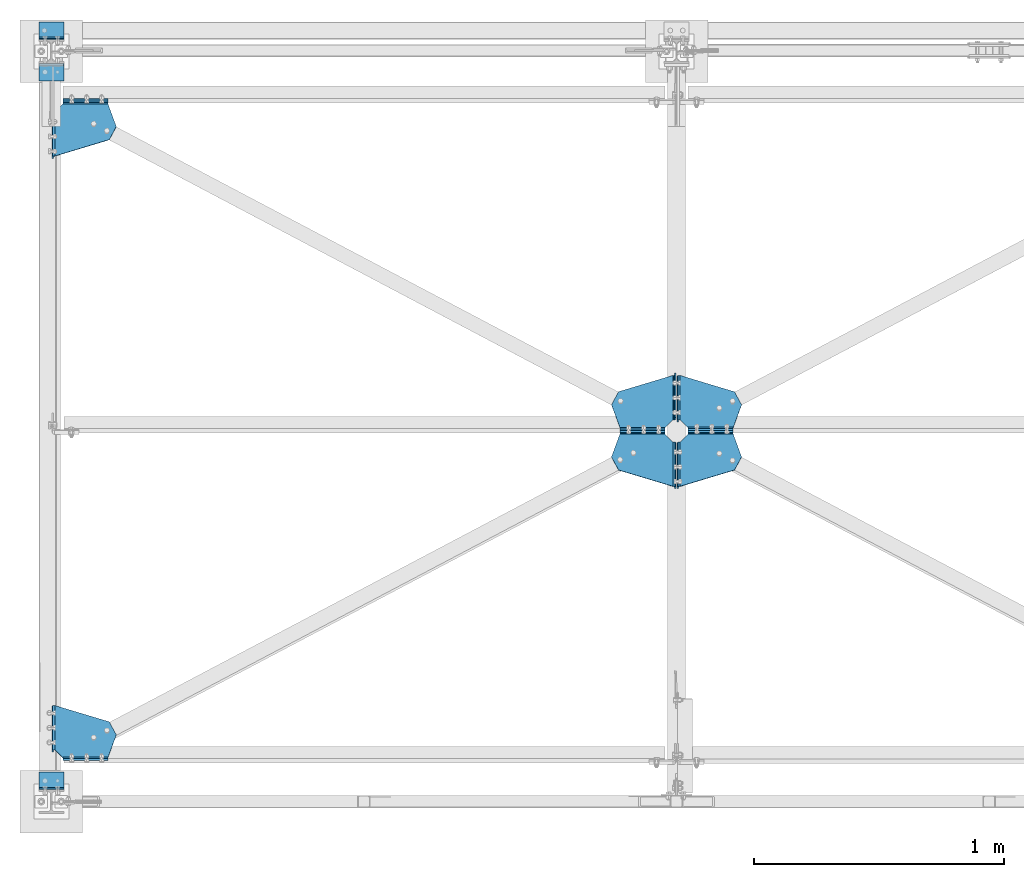
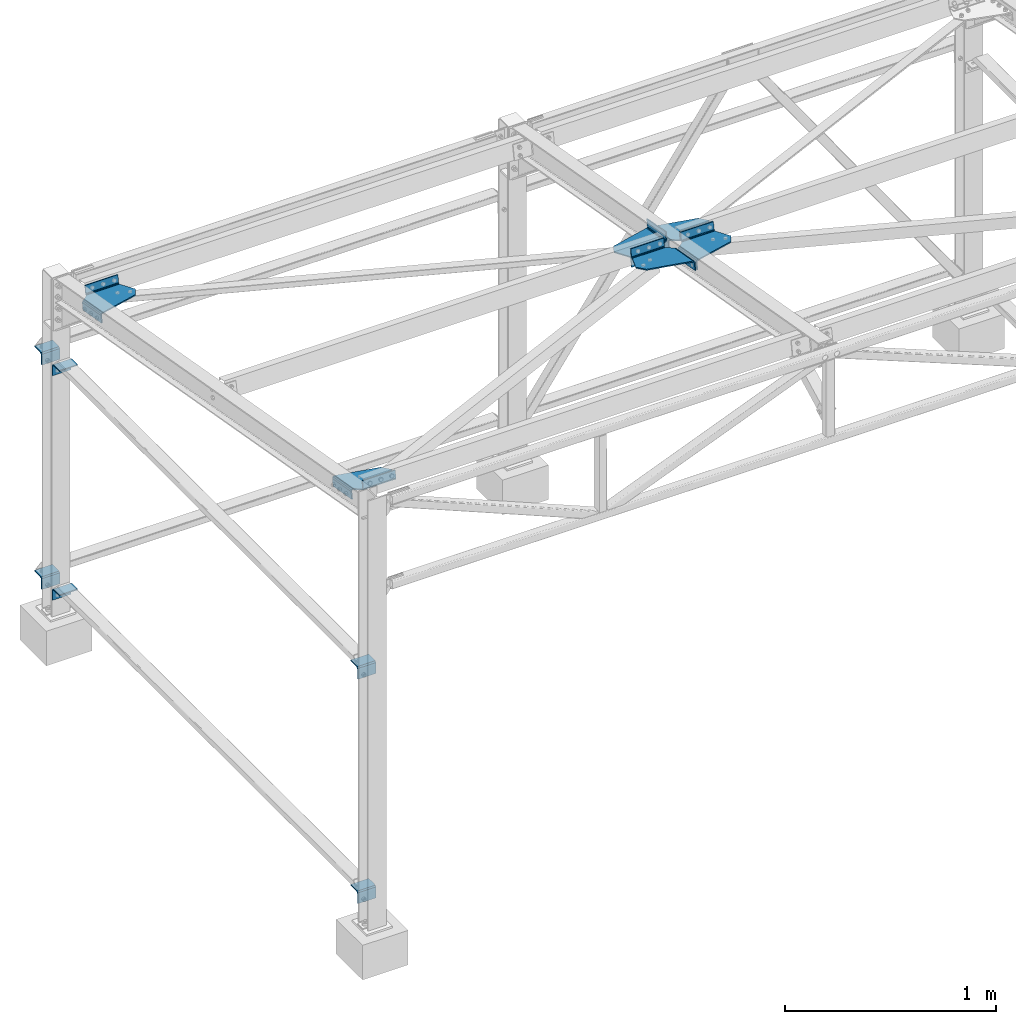
# One storey, part 14 of 28: 12 beams, 12 elements without a shape of their own.
"""IFC2X3 building model written with IfcOpenShell, lengths in millimetres."""

from ifc_helpers import new_model, si_unit, frame, origin_with_axes, place, context, subcontext, project, spatial, faceted_brep, material, type_object, element, aggregate, save


model = new_model("IFC2X3")

# Units and contexts
model_context = context("Model", 3, precision=1e-05, world=origin_with_axes())
body_context = subcontext(model_context, "Body", "Model", "MODEL_VIEW")
ifc_project = project(units=[si_unit("LENGTHUNIT", "METRE", prefix="MILLI"), si_unit("AREAUNIT", "SQUARE_METRE"), si_unit("VOLUMEUNIT", "CUBIC_METRE"), si_unit("MASSUNIT", "GRAM", prefix="KILO"), si_unit("TIMEUNIT", "SECOND"), si_unit("PLANEANGLEUNIT", "RADIAN"), si_unit("SOLIDANGLEUNIT", "STERADIAN"), si_unit("THERMODYNAMICTEMPERATUREUNIT", "DEGREE_CELSIUS"), si_unit("LUMINOUSINTENSITYUNIT", "LUMEN")], contexts=[model_context])

# Site, building, storey
site_placement = place(None, origin_with_axes())
site = spatial("IfcSite", under=ifc_project, at=site_placement, CompositionType="ELEMENT")
building_placement = place(site_placement, origin_with_axes())
building = spatial("IfcBuilding", under=site, at=building_placement, Name="Undefined", CompositionType="ELEMENT")
storey_placement = place(building_placement, origin_with_axes())
storey = spatial("IfcBuildingStorey", under=building, at=storey_placement, Name="Undefined", CompositionType="ELEMENT", Elevation=0.0)

# Assembly, beam
assembly_1_placement = place(storey_placement, origin_with_axes())
assembly_1 = element("IfcElementAssembly", 1, at=assembly_1_placement, inside=storey, Name="2", AssemblyPlace="NOTDEFINED", PredefinedType="NOTDEFINED")
ifc_material = material(Name="STEEL/S235JR")
beam_type_1 = type_object("IfcBeamType", PredefinedType="NOTDEFINED")
beam_1_placement = place(assembly_1_placement, frame((2485.82560922523, 1526.55311107342, 2359.69186909693), z_axis=(-0.999999997271612, 7.27429091355134e-05, -1.28548072275407e-05), x_axis=(7.38699999887347e-05, 0.984742281847075, -0.174019058972976)))
beam_1 = element("IfcBeam", 2, at=beam_1_placement, type_object=beam_type_1, material=ifc_material, Name="2", context=body_context, shape_type="Brep", body=[
    faceted_brep([(-32.1671295166939, -2.99999983428825, 32.1499938964121), (-32.1671295166839, -2.99999983429416, 212.154846191318), (-40.6403164354399, 0.509709106417176, 212.152998303093), (-40.6403164354474, 0.509709106422179, 32.1499938964289), (180.004760742243, -3.00000038144935, -3.91082721762359e-11), (0.0, -3.00000009420476, 0.0), (-1.52675529534463e-05, -4.75735959676012, -4.24263979950592), (180.002939800075, -4.75735959674284, -4.24263979952093), (180.001118816501, -51.0000006712148, -11.9999984741489), (180.00111885851, -9.00000043278169, -11.9999984741462), (180.00111885851, -9.00000043278214, -5.9999984741462), (180.001118816501, -51.0000006712148, -5.99999847414938), (-3.05263461086724e-05, -8.99999977819925, -5.99999809267229), (-2.55926208865276e-05, -51.0000002529223, -5.99999847413756), (-2.55926211139013e-05, -51.0000002529223, -11.9999984741371), (-2.55506129178684e-05, -9.00000025293548, -11.9999984741339), (0.0, 2.99999999999272, 0.0), (180.004760742242, 2.99999961854974, -3.86535248253495e-11), (180.002939800075, -0.514719370688454, -8.4852809477029), (-1.52675536355673e-05, -0.514719370705279, -8.4852809476879), (113.656394958525, 3.00000000000182, 217.484680175736), (113.656394958525, -2.99999999999727, 217.484680175736), (60.7738876343287, -3.00000000000136, 245.829696655227), (60.7738876343283, 2.99999999999773, 245.829696655228), (-32.1671295165343, 2.99999999999181, 212.154846191372), (-32.1671295166941, 3.00000016571084, 32.1499938964125), (-36.3976757462415, 4.75234979145444, 32.1499938964294), (-36.397675746234, 4.75234979144943, 212.152998303094), (-44.1500255336107, 8.98289602876866, 212.151145934964), (-38.1500255336107, 8.98289602275418, 212.151145934963), (-44.1500255336027, 9.0000000174291, 32.1500015258139), (-44.1500254914999, 51.0000000166533, 32.1500015258243), (-38.1500254914999, 51.0000000106388, 32.1500015258239), (-38.1500253678239, 8.98289602272507, 32.1499938964253), (-44.1500254914909, 51.0000000166137, 212.151145934974), (-38.1500254914909, 51.0000000105988, 212.151145934974)], [[[0, 1, 2, 3]], [[4, 5, 6, 7]], [[8, 9, 10, 11]], [[10, 12, 13, 11]], [[14, 8, 11, 13]], [[15, 9, 8, 14]], [[16, 17, 18, 19]], [[15, 19, 18, 9]], [[14, 13, 12, 6, 5, 16, 19, 15]], [[10, 7, 6, 12]], [[9, 18, 17, 4, 7, 10]], [[17, 20, 21, 4]], [[22, 21, 20, 23]], [[1, 22, 23, 24]], [[0, 5, 4, 21, 22, 1]], [[25, 16, 5, 0]], [[24, 23, 20, 17, 16, 25]], [[24, 25, 26, 27]], [[28, 2, 1, 24, 27, 29]], [[30, 3, 2, 28]], [[31, 32, 33, 26, 25, 0, 3, 30]], [[29, 27, 26, 33]], [[34, 31, 30, 28]], [[31, 34, 35, 32]], [[32, 35, 29, 33]], [[34, 28, 29, 35]]]),
])
aggregate(assembly_1, [beam_1])

assembly_2_placement = place(storey_placement, origin_with_axes())
assembly_2 = element("IfcElementAssembly", 3, at=assembly_2_placement, inside=storey, Name="2", AssemblyPlace="NOTDEFINED", PredefinedType="NOTDEFINED")
beam_2_placement = place(assembly_2_placement, frame((2514.35000069038, 1259.97009350943, 2406.80117727692), z_axis=(1.0, 0.0, 0.0), x_axis=(0.0, 0.984742283021841, -0.174019068003859)))
beam_2 = element("IfcBeam", 4, at=beam_2_placement, type_object=beam_type_1, material=ifc_material, Name="2", context=body_context, shape_type="Brep", body=[
    faceted_brep([(212.171890258304, 3.00000015340356, 32.1499938964184), (212.171890258359, 3.00000015328351, 212.154846191022), (216.402436487897, 4.75234977903438, 212.152999877545), (216.402436487869, 4.75234977916534, 32.1499938964134), (0.0, 2.99999999999272, 0.0), (180.004760742242, 2.99999961854974, -3.86535248253495e-11), (180.004776007459, -0.514719288806191, -8.4852808684177), (0.00182344081565589, -0.514719288739798, -8.48528086851638), (0.00364192279562303, -51.0000006707974, -5.99999847590698), (0.00364686610055287, -8.99999966160567, -5.99999809708106), (0.00364188078174266, -9.00000043237287, -11.9999984758915), (0.00364192279812414, -51.0000006707951, -11.999998475907), (180.00478628962, -9.00000025209329, -11.9999984758178), (180.00478633164, -51.0000002520987, -11.9999984758333), (180.004786331637, -51.0000002521006, -5.99999847583331), (180.004786289618, -9.00000025209602, -5.99999847581785), (180.004760742243, -3.00000038144935, -3.91082721762359e-11), (0.0, -3.00000009420476, 0.0), (0.00182344081167685, -4.75735955658729, -4.24263976212569), (180.004776007455, -4.75735955665368, -4.24263976202747), (66.3483657821899, -3.00000000178579, 217.484680173498), (66.3483657821853, 2.99999999821421, 217.484680173498), (119.230873106326, 2.99999999825377, 245.829696652969), (119.230873106331, -3.00000000174623, 245.829696652969), (212.171890258362, -2.99999984671604, 212.154846191018), (212.171890262616, -3.0000000016762, 32.1500015232709), (220.645077177092, 0.509709094149912, 32.1499938964098), (220.64507717712, 0.509709094018945, 212.152999877541), (218.154786275127, 8.98289600998714, 212.151145934432), (224.154786275127, 8.98289601609486, 212.151145934433), (218.154786275146, 8.99999999865349, 32.1500015255733), (218.154786232393, 50.9999999979341, 32.1500015229508), (224.154786232393, 51.0000000040418, 32.1500015229522), (224.154786109435, 8.98289601641636, 32.1499938964125), (218.154786232358, 50.9999999979873, 212.151145931813), (224.154786232357, 51.000000004095, 212.151145931814)], [[[0, 1, 2, 3]], [[4, 5, 6, 7]], [[8, 9, 10, 11]], [[10, 12, 13, 11]], [[14, 8, 11, 13]], [[15, 9, 8, 14]], [[16, 17, 18, 19]], [[15, 19, 18, 9]], [[14, 13, 12, 6, 5, 16, 19, 15]], [[10, 7, 6, 12]], [[9, 18, 17, 4, 7, 10]], [[17, 20, 21, 4]], [[22, 21, 20, 23]], [[1, 22, 23, 24]], [[0, 5, 4, 21, 22, 1]], [[25, 16, 5, 0]], [[24, 23, 20, 17, 16, 25]], [[24, 25, 26, 27]], [[28, 2, 1, 24, 27, 29]], [[30, 3, 2, 28]], [[31, 32, 33, 26, 25, 0, 3, 30]], [[29, 27, 26, 33]], [[34, 31, 30, 28]], [[31, 34, 35, 32]], [[32, 35, 29, 33]], [[34, 28, 29, 35]]]),
])
aggregate(assembly_2, [beam_2])

assembly_3_placement = place(storey_placement, origin_with_axes())
assembly_3 = element("IfcElementAssembly", 5, at=assembly_3_placement, inside=storey, Name="2", AssemblyPlace="NOTDEFINED", PredefinedType="NOTDEFINED")
beam_3_placement = place(assembly_3_placement, frame((2514.34999981113, 1526.23027996638, 2359.74891680608), z_axis=(1.0, 0.0, 0.0), x_axis=(0.0, 0.984742283021841, -0.174019068003859)))
beam_3 = element("IfcBeam", 6, at=beam_3_placement, type_object=beam_type_1, material=ifc_material, Name="2", context=body_context, shape_type="Brep", body=[
    faceted_brep([(-32.1671295166939, -2.99999983428825, 32.1499938964121), (-32.1671295166839, -2.99999983429416, 212.154846191318), (-40.6403164354399, 0.509709106417176, 212.152998303093), (-40.6403164354474, 0.509709106422179, 32.1499938964289), (180.004760742243, -3.00000038144935, -3.91082721762359e-11), (0.0, -3.00000009420476, 0.0), (-1.52675529534463e-05, -4.75735959676012, -4.24263979950592), (180.002939800075, -4.75735959674284, -4.24263979952093), (180.001118816501, -51.0000006712148, -11.9999984741489), (180.00111885851, -9.00000043278169, -11.9999984741462), (180.00111885851, -9.00000043278214, -5.9999984741462), (180.001118816501, -51.0000006712148, -5.99999847414938), (-3.05263461086724e-05, -8.99999977819925, -5.99999809267229), (-2.55926208865276e-05, -51.0000002529223, -5.99999847413756), (-2.55926211139013e-05, -51.0000002529223, -11.9999984741371), (-2.55506129178684e-05, -9.00000025293548, -11.9999984741339), (0.0, 2.99999999999272, 0.0), (180.004760742242, 2.99999961854974, -3.86535248253495e-11), (180.002939800075, -0.514719370688454, -8.4852809477029), (-1.52675536355673e-05, -0.514719370705279, -8.4852809476879), (113.656394958525, 3.00000000000182, 217.484680175736), (113.656394958525, -2.99999999999727, 217.484680175736), (60.7738876343287, -3.00000000000136, 245.829696655227), (60.7738876343283, 2.99999999999773, 245.829696655228), (-32.1671295165343, 2.99999999999181, 212.154846191372), (-32.1671295166941, 3.00000016571084, 32.1499938964125), (-36.3976757462415, 4.75234979145444, 32.1499938964294), (-36.397675746234, 4.75234979144943, 212.152998303094), (-44.1500255336107, 8.98289602876866, 212.151145934964), (-38.1500255336107, 8.98289602275418, 212.151145934963), (-44.1500255336027, 9.0000000174291, 32.1500015258139), (-44.1500254914999, 51.0000000166533, 32.1500015258243), (-38.1500254914999, 51.0000000106388, 32.1500015258239), (-38.1500253678239, 8.98289602272507, 32.1499938964253), (-44.1500254914909, 51.0000000166137, 212.151145934974), (-38.1500254914909, 51.0000000105988, 212.151145934974)], [[[0, 1, 2, 3]], [[4, 5, 6, 7]], [[8, 9, 10, 11]], [[10, 12, 13, 11]], [[14, 8, 11, 13]], [[15, 9, 8, 14]], [[16, 17, 18, 19]], [[15, 19, 18, 9]], [[14, 13, 12, 6, 5, 16, 19, 15]], [[10, 7, 6, 12]], [[9, 18, 17, 4, 7, 10]], [[17, 20, 21, 4]], [[22, 21, 20, 23]], [[1, 22, 23, 24]], [[0, 5, 4, 21, 22, 1]], [[25, 16, 5, 0]], [[24, 23, 20, 17, 16, 25]], [[24, 25, 26, 27]], [[28, 2, 1, 24, 27, 29]], [[30, 3, 2, 28]], [[31, 32, 33, 26, 25, 0, 3, 30]], [[29, 27, 26, 33]], [[34, 31, 30, 28]], [[31, 34, 35, 32]], [[32, 35, 29, 33]], [[34, 28, 29, 35]]]),
])
aggregate(assembly_3, [beam_3])

assembly_4_placement = place(storey_placement, origin_with_axes())
assembly_4 = element("IfcElementAssembly", 7, at=assembly_4_placement, inside=storey, Name="2", AssemblyPlace="NOTDEFINED", PredefinedType="NOTDEFINED")
beam_4_placement = place(assembly_4_placement, frame((2485.64999885867, 1259.97009239422, 2406.8011763732), z_axis=(-1.0, 0.0, 0.0), x_axis=(0.0, 0.984742283021841, -0.174019068003859)))
beam_4 = element("IfcBeam", 8, at=beam_4_placement, type_object=beam_type_1, material=ifc_material, Name="2", context=body_context, shape_type="Brep", body=[
    faceted_brep([(212.171890258362, -2.99999984671604, 212.154846191018), (212.171890262616, -3.0000000016762, 32.1500015232709), (216.402436417659, -4.75234984434974, 32.1499939661526), (216.402436417649, -4.75234984434655, 212.152999947595), (180.004760742243, -3.00000038144935, -3.91082721762359e-11), (0.0, -3.00000009420476, 0.0), (0.00182344546442437, 0.514719367938596, -8.48528094933317), (180.004776030061, 0.514719367933139, -8.48528094933909), (119.230873106326, 2.99999999825377, 245.829696652969), (66.3483657821853, 2.99999999821421, 217.484680173498), (66.3483657821899, -3.00000000178579, 217.484680173498), (119.230873106331, -3.00000000174623, 245.829696652969), (0.0, 2.99999999999272, 0.0), (180.00479128885, 9.00000107956885, -11.9999980942903), (0.00364190111224616, 9.00000037021528, -11.9999984245605), (0.00364194311600841, 51.000000608894, -11.9999984245605), (180.004786352339, 51.000000190174, -11.9999984245587), (0.00364190111201879, 9.00000037021528, -5.99999842456054), (0.00364194311600841, 51.0000006088935, -5.99999842456054), (180.004786352339, 51.000000190174, -5.99999842455873), (180.004786310335, 9.00000019020126, -5.99999842455873), (180.004760742242, 2.99999961854974, -3.86535248253495e-11), (180.004776030061, 4.75735959397207, -4.24263980113983), (0.00182344546442437, 4.75735959397753, -4.24263980113437), (212.171890258304, 3.00000015340356, 32.1499938964184), (212.171890258359, 3.00000015328351, 212.154846191022), (220.645077106859, -0.5097091593193, 212.152999947595), (220.64507710687, -0.509709159322483, 32.1499939661526), (224.154786205036, -8.98289611563087, 32.1500015982069), (224.154786205021, -8.99999985471231, 212.151146007386), (218.154786039228, -8.98289607562765, 212.15115363412), (218.154786205036, -8.98289610954862, 32.1500015982069), (218.154786162447, -51.0000000781347, 212.151146004903), (218.154786162444, -51.0000000780733, 32.1500015957245), (224.154786162445, -51.0000000841551, 32.1500015957245), (224.154786162447, -51.0000000842165, 212.151146004903)], [[[0, 1, 2, 3]], [[4, 5, 6, 7]], [[8, 9, 10, 11]], [[5, 10, 9, 12]], [[13, 14, 15, 16]], [[15, 14, 17, 18]], [[16, 15, 18, 19]], [[17, 20, 19, 18]], [[12, 21, 22, 23]], [[17, 23, 22, 20]], [[14, 6, 5, 12, 23, 17]], [[13, 7, 6, 14]], [[16, 19, 20, 22, 21, 4, 7, 13]], [[1, 4, 21, 24]], [[0, 11, 10, 5, 4, 1]], [[25, 8, 11, 0]], [[24, 21, 12, 9, 8, 25]], [[24, 25, 26, 27]], [[28, 27, 26, 29]], [[30, 3, 2, 31]], [[29, 26, 25, 0, 3, 30]], [[32, 33, 34, 35]], [[30, 32, 35, 29]], [[33, 32, 30, 31]], [[33, 31, 2, 1, 24, 27, 28, 34]], [[35, 34, 28, 29]]]),
])
aggregate(assembly_4, [beam_4])

assembly_5_placement = place(storey_placement, origin_with_axes())
assembly_5 = element("IfcElementAssembly", 9, at=assembly_5_placement, inside=storey, Name="2", AssemblyPlace="NOTDEFINED", PredefinedType="NOTDEFINED")
beam_5_placement = place(assembly_5_placement, frame((14.3500001059313, 2757.8578579446, 2142.10143063266), z_axis=(1.0, 0.0, 0.0), x_axis=(0.0, -0.984742283021841, 0.17401906800386)))
beam_5 = element("IfcBeam", 10, at=beam_5_placement, type_object=beam_type_1, material=ifc_material, Name="2", context=body_context, shape_type="Brep", body=[
    faceted_brep([(-32.1671295165343, 2.99999999999181, 212.154846191372), (-32.1671295166941, 3.00000016571084, 32.1499938964125), (-40.6403164367075, -0.509709095669223, 32.1499938980763), (-40.6403164366952, -0.509709095670132, 212.15299987956), (0.0, 2.99999999999272, 0.0), (180.004760742242, 2.99999961854974, -3.86535248253495e-11), (180.002937299718, 4.75735955505934, -4.24263976038337), (-1.52670218085404e-05, 4.7573595550889, -4.24263976037983), (60.7738876343287, -3.00000000000136, 245.829696655227), (113.656394958525, -2.99999999999727, 217.484680175736), (113.656394958525, 3.00000000000182, 217.484680175736), (60.7738876343283, 2.99999999999773, 245.829696655228), (180.004760742243, -3.00000038144935, -3.91082721762359e-11), (-2.55477848440933e-05, 9.00000025060126, -5.99999848867704), (180.001118861344, 9.00000043080399, -5.99999848867694), (180.001118819345, 51.0000006694813, -5.99999848867695), (-2.55897848546738e-05, 51.0000002505694, -5.99999848867705), (180.001113874432, 9.00000084603289, -11.9999980953256), (180.001118819345, 51.0000006694813, -11.999998488677), (-2.55897848546738e-05, 51.0000002505694, -11.9999984886771), (-2.55477848440933e-05, 9.00000025060126, -11.999998488677), (0.0, -3.00000009420476, 0.0), (-1.52670222632878e-05, 0.514719287256412, -8.48528086678614), (180.002937299717, 0.514719287227763, -8.48528086678967), (-32.1671295166939, -2.99999983428825, 32.1499938964121), (-32.1671295166839, -2.99999983429416, 212.154846191318), (-36.3976757474693, -4.75234978068238, 212.15299987956), (-36.3976757474811, -4.75234978068102, 32.149993898076), (-38.1500255347992, -9.00000000026193, 32.150001527229), (-38.1500255348169, -8.98289601158194, 212.151145936418), (-38.1500254930233, -50.9999999995471, 32.1500015391552), (-44.1500254930229, -51.0000000055152, 32.1500015391552), (-44.1500255347983, -9.00000000622958, 32.150001527229), (-44.1500253690306, -8.98289601795022, 212.151153566087), (-38.1500254930238, -50.999999999618, 212.151145948344), (-44.1500254930238, -51.0000000055852, 212.151145948344)], [[[0, 1, 2, 3]], [[4, 5, 6, 7]], [[8, 9, 10, 11]], [[5, 10, 9, 12]], [[13, 14, 15, 16]], [[15, 14, 17, 18]], [[16, 15, 18, 19]], [[17, 20, 19, 18]], [[12, 21, 22, 23]], [[17, 23, 22, 20]], [[14, 6, 5, 12, 23, 17]], [[13, 7, 6, 14]], [[16, 19, 20, 22, 21, 4, 7, 13]], [[1, 4, 21, 24]], [[0, 11, 10, 5, 4, 1]], [[25, 8, 11, 0]], [[24, 21, 12, 9, 8, 25]], [[24, 25, 26, 27]], [[28, 27, 26, 29]], [[30, 31, 32, 2, 1, 24, 27, 28]], [[33, 3, 2, 32]], [[29, 26, 25, 0, 3, 33]], [[30, 34, 35, 31]], [[34, 29, 33, 35]], [[31, 35, 33, 32]], [[34, 30, 28, 29]]]),
])
aggregate(assembly_5, [beam_5])

assembly_6_placement = place(storey_placement, origin_with_axes())
assembly_6 = element("IfcElementAssembly", 11, at=assembly_6_placement, inside=storey, Name="1", AssemblyPlace="NOTDEFINED", PredefinedType="NOTDEFINED")
beam_6_placement = place(assembly_6_placement, frame((14.3499999055751, 383.933919863615, 2561.61020728399), z_axis=(1.0, 0.0, 0.0), x_axis=(0.0, -0.984742283021841, 0.17401906800386)))
beam_6 = element("IfcBeam", 12, at=beam_6_placement, type_object=beam_type_1, material=ifc_material, Name="1", context=body_context, shape_type="Brep", body=[
    faceted_brep([(212.171890258362, -2.99999984671604, 212.154846191018), (212.171890262616, -3.0000000016762, 32.1500015232709), (216.402436417659, -4.75234984434974, 32.1499939661526), (216.402436417649, -4.75234984434655, 212.152999947595), (180.004760742243, -3.00000038144935, -3.91082721762359e-11), (0.0, -3.00000009420476, 0.0), (0.00182344546442437, 0.514719367938596, -8.48528094933317), (180.004776030061, 0.514719367933139, -8.48528094933909), (119.230873106326, 2.99999999825377, 245.829696652969), (66.3483657821853, 2.99999999821421, 217.484680173498), (66.3483657821899, -3.00000000178579, 217.484680173498), (119.230873106331, -3.00000000174623, 245.829696652969), (0.0, 2.99999999999272, 0.0), (180.00479128885, 9.00000107956885, -11.9999980942903), (0.00364190111224616, 9.00000037021528, -11.9999984245605), (0.00364194311600841, 51.000000608894, -11.9999984245605), (180.004786352339, 51.000000190174, -11.9999984245587), (0.00364190111201879, 9.00000037021528, -5.99999842456054), (0.00364194311600841, 51.0000006088935, -5.99999842456054), (180.004786352339, 51.000000190174, -5.99999842455873), (180.004786310335, 9.00000019020126, -5.99999842455873), (180.004760742242, 2.99999961854974, -3.86535248253495e-11), (180.004776030061, 4.75735959397207, -4.24263980113983), (0.00182344546442437, 4.75735959397753, -4.24263980113437), (212.171890258304, 3.00000015340356, 32.1499938964184), (212.171890258359, 3.00000015328351, 212.154846191022), (220.645077106859, -0.5097091593193, 212.152999947595), (220.64507710687, -0.509709159322483, 32.1499939661526), (224.154786275888, -9.00000001742183, 32.1500015258126), (224.154786275905, -8.98289602874456, 212.151145935003), (224.154786162445, -51.0000000841551, 32.1500015957245), (218.154786162444, -51.0000000780733, 32.1500015957245), (218.154786275888, -9.00000001144599, 32.1500015258126), (218.154786039228, -8.98289607562765, 212.15115363412), (218.154786162447, -51.0000000781347, 212.151146004903), (224.154786162447, -51.0000000842165, 212.151146004903)], [[[0, 1, 2, 3]], [[4, 5, 6, 7]], [[8, 9, 10, 11]], [[5, 10, 9, 12]], [[13, 14, 15, 16]], [[15, 14, 17, 18]], [[16, 15, 18, 19]], [[17, 20, 19, 18]], [[12, 21, 22, 23]], [[17, 23, 22, 20]], [[14, 6, 5, 12, 23, 17]], [[13, 7, 6, 14]], [[16, 19, 20, 22, 21, 4, 7, 13]], [[1, 4, 21, 24]], [[0, 11, 10, 5, 4, 1]], [[25, 8, 11, 0]], [[24, 21, 12, 9, 8, 25]], [[24, 25, 26, 27]], [[28, 27, 26, 29]], [[30, 31, 32, 2, 1, 24, 27, 28]], [[33, 3, 2, 32]], [[29, 26, 25, 0, 3, 33]], [[34, 31, 30, 35]], [[35, 29, 33, 34]], [[31, 34, 33, 32]], [[35, 30, 28, 29]]]),
])
aggregate(assembly_6, [beam_6])

assembly_7_placement = place(storey_placement, origin_with_axes())
assembly_7 = element("IfcElementAssembly", 13, at=assembly_7_placement, inside=storey, Name="Support-Lisse", AssemblyPlace="NOTDEFINED", PredefinedType="NOTDEFINED")
beam_type_2 = type_object("IfcBeamType", PredefinedType="NOTDEFINED")
beam_7_placement = place(assembly_7_placement, frame((-50.0000000003879, 2949.0000000009, 361.999895901674), z_axis=(0.0, 0.0, -1.0), x_axis=(1.0, 0.0, 0.0)))
beam_7 = element("IfcBeam", 14, at=beam_7_placement, type_object=beam_type_2, material=ifc_material, Name="Support-Lisse", context=body_context, shape_type="Brep", body=[
    faceted_brep([(100.000000000007, -0.588457268122056, -8.99999999999545), (-6.11066752753686e-13, -0.588457268120692, -8.99999999999545), (-1.12976294985856e-12, 5.99999999999682, -15.5884572681151), (100.000000000006, 5.99999999999545, -15.5884572681151), (100.000000000007, -3.00000000000136, 2.95585778076202e-12), (0.0, -3.00000009420476, 0.0), (100.000000000009, -3.0, 52.0000000000091), (1.81898940354586e-12, -3.0, 52.0000000000086), (100.000000000009, 3.0, 52.0000000000091), (1.81898940354586e-12, 3.0, 52.0000000000086), (0.0, 2.99999999999272, 0.0), (100.000000000007, 2.99999999999864, 2.95585778076202e-12), (100.000000000007, 4.60769515458469, -5.99999999999602), (-5.40012479177676e-13, 4.60769515458605, -5.99999999999602), (100.000000000006, 8.99999999999636, -10.3923048454091), (-1.08713038571295e-12, 8.99999999999773, -10.3923048454091), (7.105427357601e-15, 14.9999999999968, -11.9999999999886), (100.000000000007, 14.9999999999968, -11.9999999999889), (100.000000000006, 14.9999999999932, -17.999999999997), (-7.105427357601e-15, 14.9999999999968, -17.9999999999886), (100.000000000005, 66.9999999999968, -17.9999999999886), (100.000000000005, 66.9999999999968, -11.9999999999886), (-1.82609483090346e-12, 66.9999999999968, -17.9999999999884), (-1.81188397618826e-12, 66.9999999999968, -11.9999999999884)], [[[0, 1, 2, 3]], [[4, 5, 1, 0]], [[4, 6, 7, 5]], [[7, 6, 8, 9]], [[10, 9, 8, 11]], [[10, 11, 12, 13]], [[13, 12, 14, 15]], [[16, 15, 14, 17]], [[18, 3, 2, 19]], [[20, 21, 17, 14, 12, 11, 8, 6, 4, 0, 3, 18]], [[20, 22, 23, 21]], [[20, 18, 19, 22]], [[22, 19, 2, 1, 5, 7, 9, 10, 13, 15, 16, 23]], [[17, 21, 23, 16]]]),
])
aggregate(assembly_7, [beam_7])

assembly_8_placement = place(storey_placement, origin_with_axes())
assembly_8 = element("IfcElementAssembly", 15, at=assembly_8_placement, inside=storey, Name="Support-Lisse", AssemblyPlace="NOTDEFINED", PredefinedType="NOTDEFINED")
beam_8_placement = place(assembly_8_placement, frame((-50.0000000003879, 2949.00000000016, 1661.99989590197), z_axis=(0.0, 0.0, -1.0), x_axis=(1.0, 0.0, 0.0)))
beam_8 = element("IfcBeam", 16, at=beam_8_placement, type_object=beam_type_2, material=ifc_material, Name="Support-Lisse", context=body_context, shape_type="Brep", body=[
    faceted_brep([(100.000000000007, -0.588457268122056, -8.99999999999545), (-6.11066752753686e-13, -0.588457268120692, -8.99999999999545), (-1.12976294985856e-12, 5.99999999999682, -15.5884572681151), (100.000000000006, 5.99999999999545, -15.5884572681151), (100.000000000007, -3.00000000000136, 2.95585778076202e-12), (0.0, -3.00000009420476, 0.0), (100.000000000009, -3.0, 52.0000000000091), (1.81898940354586e-12, -3.0, 52.0000000000086), (100.000000000009, 3.0, 52.0000000000091), (1.81898940354586e-12, 3.0, 52.0000000000086), (0.0, 2.99999999999272, 0.0), (100.000000000007, 2.99999999999864, 2.95585778076202e-12), (100.000000000007, 4.60769515458469, -5.99999999999602), (-5.40012479177676e-13, 4.60769515458605, -5.99999999999602), (100.000000000006, 8.99999999999636, -10.3923048454091), (-1.08713038571295e-12, 8.99999999999773, -10.3923048454091), (7.105427357601e-15, 14.9999999999968, -11.9999999999886), (100.000000000007, 14.9999999999968, -11.9999999999889), (100.000000000006, 14.9999999999932, -17.999999999997), (-7.105427357601e-15, 14.9999999999968, -17.9999999999886), (100.000000000005, 66.9999999999968, -17.9999999999886), (100.000000000005, 66.9999999999968, -11.9999999999886), (-1.82609483090346e-12, 66.9999999999968, -17.9999999999884), (-1.81188397618826e-12, 66.9999999999968, -11.9999999999884)], [[[0, 1, 2, 3]], [[4, 5, 1, 0]], [[4, 6, 7, 5]], [[7, 6, 8, 9]], [[10, 9, 8, 11]], [[10, 11, 12, 13]], [[13, 12, 14, 15]], [[16, 15, 14, 17]], [[18, 3, 2, 19]], [[20, 21, 17, 14, 12, 11, 8, 6, 4, 0, 3, 18]], [[20, 22, 23, 21]], [[20, 18, 19, 22]], [[22, 19, 2, 1, 5, 7, 9, 10, 13, 15, 16, 23]], [[17, 21, 23, 16]]]),
])
aggregate(assembly_8, [beam_8])

assembly_9_placement = place(storey_placement, origin_with_axes())
assembly_9 = element("IfcElementAssembly", 17, at=assembly_9_placement, inside=storey, Name="Support-Lisse", AssemblyPlace="NOTDEFINED", PredefinedType="NOTDEFINED")
beam_9_placement = place(assembly_9_placement, frame((-50.0000000003879, 51.0000000008999, 361.999895901674), z_axis=(0.0, 0.0, -1.0), x_axis=(1.0, 0.0, 0.0)))
beam_9 = element("IfcBeam", 18, at=beam_9_placement, type_object=beam_type_2, material=ifc_material, Name="Support-Lisse", context=body_context, shape_type="Brep", body=[
    faceted_brep([(1.4210854715202e-14, 0.588457268119349, -9.00000000000369), (100.000000000007, 0.588457268117985, -9.00000000000369), (100.000000000007, -6.00000000000325, -15.5884572681237), (-8.5265128291212e-14, -6.00000000000189, -15.5884572681237), (0.0, 2.99999999999272, 0.0), (100.000000000007, 2.99999999999864, 2.95585778076202e-12), (1.81898940354586e-12, 3.0, 52.0000000000086), (100.000000000009, 3.0, 52.0000000000091), (1.81898940354586e-12, -3.0, 52.0000000000086), (100.000000000009, -3.0, 52.0000000000091), (100.000000000007, -3.00000000000136, 2.95585778076202e-12), (0.0, -3.00000009420476, 0.0), (-5.6843418860808e-14, -4.6076951545871, -6.00000000000335), (100.000000000007, -4.60769515458846, -6.00000000000335), (-1.27897692436818e-13, -9.00000000000126, -10.3923048454167), (100.000000000007, -9.00000000000262, -10.3923048454167), (-1.80477854883065e-12, -14.9999999999991, -18.000000000015), (100.000000000005, -14.9999999999991, -18.000000000015), (1.4210854715202e-14, -66.9999999999991, -18.0000000000152), (1.4210854715202e-14, -66.9999999999991, -12.0000000000152), (-1.98951966012828e-13, -15.0000000000022, -12.0000000000027), (100.000000000005, -14.9999999999991, -12.000000000015), (100.000000000007, -66.9999999999991, -18.0000000000152), (100.000000000007, -66.9999999999991, -12.0000000000152)], [[[0, 1, 2, 3]], [[4, 5, 1, 0]], [[4, 6, 7, 5]], [[8, 9, 7, 6]], [[10, 9, 8, 11]], [[10, 11, 12, 13]], [[13, 12, 14, 15]], [[16, 3, 2, 17]], [[18, 19, 20, 14, 12, 11, 8, 6, 4, 0, 3, 16]], [[21, 15, 14, 20]], [[18, 16, 17, 22]], [[18, 22, 23, 19]], [[20, 19, 23, 21]], [[22, 17, 2, 1, 5, 7, 9, 10, 13, 15, 21, 23]]]),
])
aggregate(assembly_9, [beam_9])

assembly_10_placement = place(storey_placement, origin_with_axes())
assembly_10 = element("IfcElementAssembly", 19, at=assembly_10_placement, inside=storey, Name="Support-Lisse", AssemblyPlace="NOTDEFINED", PredefinedType="NOTDEFINED")
beam_10_placement = place(assembly_10_placement, frame((-50.0000000003879, 51.000000000161, 1661.99989590197), z_axis=(0.0, 0.0, -1.0), x_axis=(1.0, 0.0, 0.0)))
beam_10 = element("IfcBeam", 20, at=beam_10_placement, type_object=beam_type_2, material=ifc_material, Name="Support-Lisse", context=body_context, shape_type="Brep", body=[
    faceted_brep([(1.4210854715202e-14, 0.588457268119349, -9.00000000000369), (100.000000000007, 0.588457268117985, -9.00000000000369), (100.000000000007, -6.00000000000325, -15.5884572681237), (-8.5265128291212e-14, -6.00000000000189, -15.5884572681237), (0.0, 2.99999999999272, 0.0), (100.000000000007, 2.99999999999864, 2.95585778076202e-12), (1.81898940354586e-12, 3.0, 52.0000000000086), (100.000000000009, 3.0, 52.0000000000091), (1.81898940354586e-12, -3.0, 52.0000000000086), (100.000000000009, -3.0, 52.0000000000091), (100.000000000007, -3.00000000000136, 2.95585778076202e-12), (0.0, -3.00000009420476, 0.0), (-5.6843418860808e-14, -4.6076951545871, -6.00000000000335), (100.000000000007, -4.60769515458846, -6.00000000000335), (-1.27897692436818e-13, -9.00000000000126, -10.3923048454167), (100.000000000007, -9.00000000000262, -10.3923048454167), (-1.80477854883065e-12, -14.9999999999991, -18.000000000015), (100.000000000005, -14.9999999999991, -18.000000000015), (1.4210854715202e-14, -66.9999999999991, -18.0000000000152), (1.4210854715202e-14, -66.9999999999991, -12.0000000000152), (-1.98951966012828e-13, -15.0000000000022, -12.0000000000027), (100.000000000005, -14.9999999999991, -12.000000000015), (100.000000000007, -66.9999999999991, -18.0000000000152), (100.000000000007, -66.9999999999991, -12.0000000000152)], [[[0, 1, 2, 3]], [[4, 5, 1, 0]], [[4, 6, 7, 5]], [[8, 9, 7, 6]], [[10, 9, 8, 11]], [[10, 11, 12, 13]], [[13, 12, 14, 15]], [[16, 3, 2, 17]], [[18, 19, 20, 14, 12, 11, 8, 6, 4, 0, 3, 16]], [[21, 15, 14, 20]], [[18, 16, 17, 22]], [[18, 22, 23, 19]], [[20, 19, 23, 21]], [[22, 17, 2, 1, 5, 7, 9, 10, 13, 15, 21, 23]]]),
])
aggregate(assembly_10, [beam_10])

assembly_11_placement = place(storey_placement, origin_with_axes())
assembly_11 = element("IfcElementAssembly", 21, at=assembly_11_placement, inside=storey, Name="Support-Lisse", AssemblyPlace="NOTDEFINED", PredefinedType="NOTDEFINED")
beam_11_placement = place(assembly_11_placement, frame((49.9999999994129, 3051.00000000115, 361.999895901142), z_axis=(0.0, 0.0, -1.0), x_axis=(-1.0, 0.0, 0.0)))
beam_11 = element("IfcBeam", 22, at=beam_11_placement, type_object=beam_type_2, material=ifc_material, Name="Support-Lisse", context=body_context, shape_type="Brep", body=[
    faceted_brep([(100.000000000007, -0.588457268122056, -8.99999999999545), (-6.11066752753686e-13, -0.588457268120692, -8.99999999999545), (-1.12976294985856e-12, 5.99999999999682, -15.5884572681151), (100.000000000006, 5.99999999999545, -15.5884572681151), (100.000000000007, -3.00000000000136, 2.95585778076202e-12), (0.0, -3.00000009420476, 0.0), (100.000000000009, -3.0, 52.0000000000091), (1.81898940354586e-12, -3.0, 52.0000000000086), (100.000000000009, 3.0, 52.0000000000091), (1.81898940354586e-12, 3.0, 52.0000000000086), (0.0, 2.99999999999272, 0.0), (100.000000000007, 2.99999999999864, 2.95585778076202e-12), (100.000000000007, 4.60769515458469, -5.99999999999602), (-5.40012479177676e-13, 4.60769515458605, -5.99999999999602), (100.000000000006, 8.99999999999636, -10.3923048454091), (-1.08713038571295e-12, 8.99999999999773, -10.3923048454091), (7.105427357601e-15, 14.9999999999968, -11.9999999999886), (100.000000000007, 14.9999999999968, -11.9999999999889), (100.000000000006, 14.9999999999932, -17.999999999997), (-7.105427357601e-15, 14.9999999999968, -17.9999999999886), (100.000000000005, 66.9999999999968, -17.9999999999886), (100.000000000005, 66.9999999999968, -11.9999999999886), (-1.82609483090346e-12, 66.9999999999968, -17.9999999999884), (-1.81188397618826e-12, 66.9999999999968, -11.9999999999884)], [[[0, 1, 2, 3]], [[4, 5, 1, 0]], [[4, 6, 7, 5]], [[7, 6, 8, 9]], [[10, 9, 8, 11]], [[10, 11, 12, 13]], [[13, 12, 14, 15]], [[16, 15, 14, 17]], [[18, 3, 2, 19]], [[20, 21, 17, 14, 12, 11, 8, 6, 4, 0, 3, 18]], [[20, 22, 23, 21]], [[20, 18, 19, 22]], [[22, 19, 2, 1, 5, 7, 9, 10, 13, 15, 16, 23]], [[17, 21, 23, 16]]]),
])
aggregate(assembly_11, [beam_11])

assembly_12_placement = place(storey_placement, origin_with_axes())
assembly_12 = element("IfcElementAssembly", 23, at=assembly_12_placement, inside=storey, Name="Support-Lisse", AssemblyPlace="NOTDEFINED", PredefinedType="NOTDEFINED")
beam_12_placement = place(assembly_12_placement, frame((49.999999999412, 3051.00000000025, 1661.99989590153), z_axis=(0.0, 0.0, -1.0), x_axis=(-1.0, 0.0, 0.0)))
beam_12 = element("IfcBeam", 24, at=beam_12_placement, type_object=beam_type_2, material=ifc_material, Name="Support-Lisse", context=body_context, shape_type="Brep", body=[
    faceted_brep([(100.000000000007, -0.588457268122056, -8.99999999999545), (-6.11066752753686e-13, -0.588457268120692, -8.99999999999545), (-1.12976294985856e-12, 5.99999999999682, -15.5884572681151), (100.000000000006, 5.99999999999545, -15.5884572681151), (100.000000000007, -3.00000000000136, 2.95585778076202e-12), (0.0, -3.00000009420476, 0.0), (100.000000000009, -3.0, 52.0000000000091), (1.81898940354586e-12, -3.0, 52.0000000000086), (100.000000000009, 3.0, 52.0000000000091), (1.81898940354586e-12, 3.0, 52.0000000000086), (0.0, 2.99999999999272, 0.0), (100.000000000007, 2.99999999999864, 2.95585778076202e-12), (100.000000000007, 4.60769515458469, -5.99999999999602), (-5.40012479177676e-13, 4.60769515458605, -5.99999999999602), (100.000000000006, 8.99999999999636, -10.3923048454091), (-1.08713038571295e-12, 8.99999999999773, -10.3923048454091), (7.105427357601e-15, 14.9999999999968, -11.9999999999886), (100.000000000007, 14.9999999999968, -11.9999999999889), (100.000000000006, 14.9999999999932, -17.999999999997), (-7.105427357601e-15, 14.9999999999968, -17.9999999999886), (100.000000000005, 66.9999999999968, -17.9999999999886), (100.000000000005, 66.9999999999968, -11.9999999999886), (-1.82609483090346e-12, 66.9999999999968, -17.9999999999884), (-1.81188397618826e-12, 66.9999999999968, -11.9999999999884)], [[[0, 1, 2, 3]], [[4, 5, 1, 0]], [[4, 6, 7, 5]], [[7, 6, 8, 9]], [[10, 9, 8, 11]], [[10, 11, 12, 13]], [[13, 12, 14, 15]], [[16, 15, 14, 17]], [[18, 3, 2, 19]], [[20, 21, 17, 14, 12, 11, 8, 6, 4, 0, 3, 18]], [[20, 22, 23, 21]], [[20, 18, 19, 22]], [[22, 19, 2, 1, 5, 7, 9, 10, 13, 15, 16, 23]], [[17, 21, 23, 16]]]),
])
aggregate(assembly_12, [beam_12])

save(model, "model.ifc")
